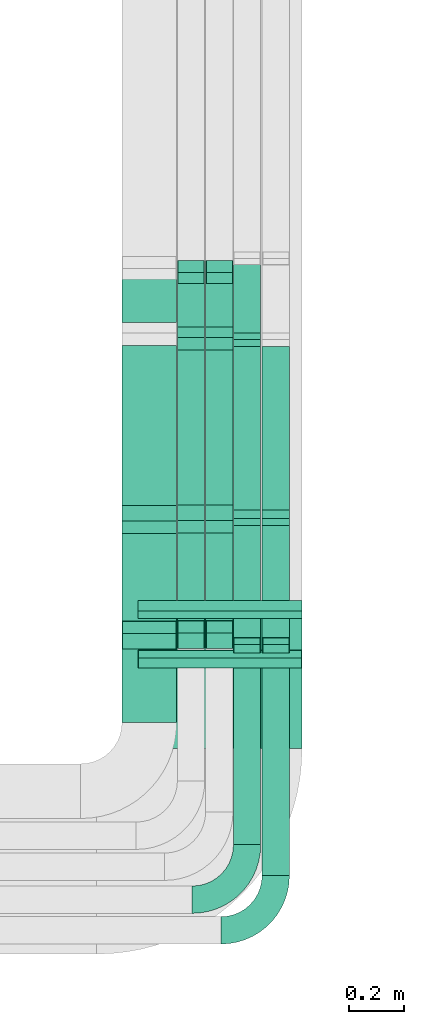
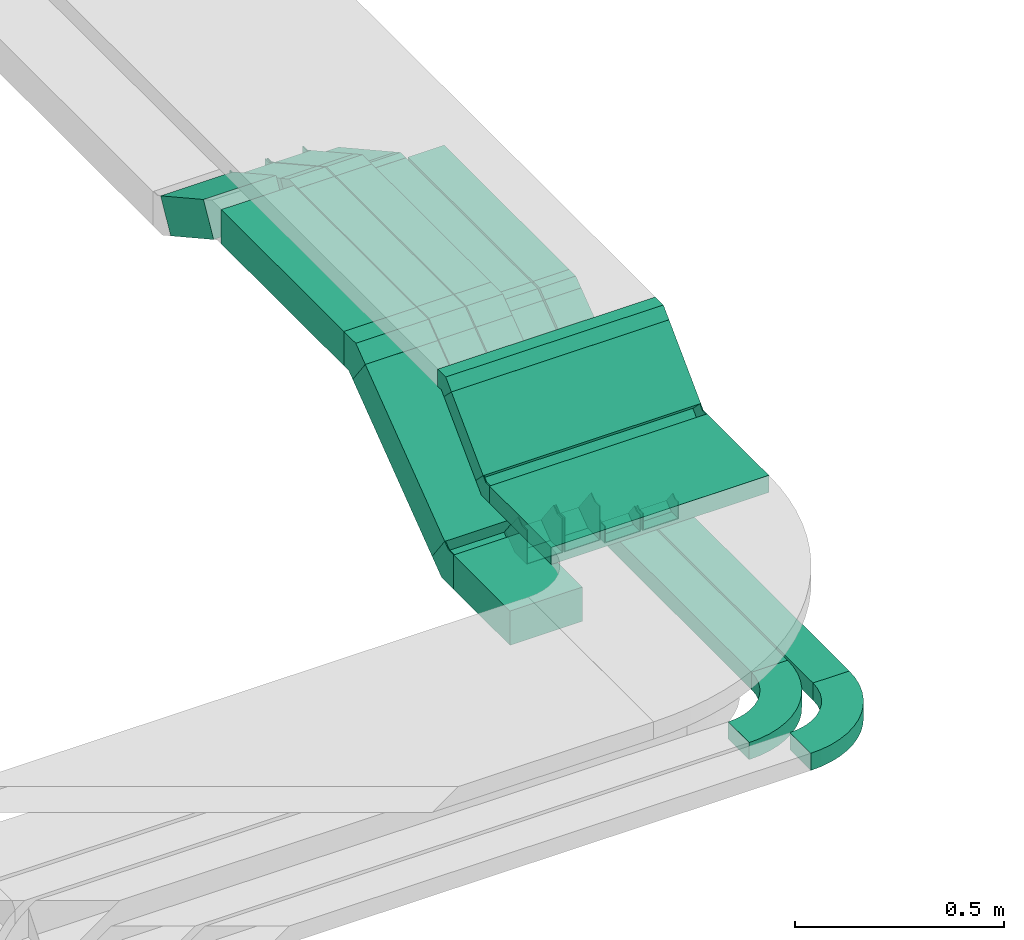
# One storey, part 24 of 38: 19 flow fittings, 19 flow segments.
"""IFC2X3 building model written with IfcOpenShell, lengths in millimetres."""

from ifc_helpers import new_model, entity, si_unit, converted_unit, derived_unit, direction, frame, frame_2d, origin, origin_2d_with_axis, place, context, subcontext, project, spatial, polyline, circle_curve, parameter, trimmed, segment, composite_curve, rectangle, outline, extrude, faceted_brep, source, transform, mapped, material, type_object, type_shapes, element, save


model = new_model("IFC2X3")

# Units and contexts
model_context = context("Model", 3, precision=0.01, world=origin(), true_north=direction((6.12303176911189e-17, 1.0)))
body_context = subcontext(model_context, "Body", "Model", "MODEL_VIEW")
ifc_project = project(units=[si_unit("LENGTHUNIT", "METRE", prefix="MILLI"), si_unit("AREAUNIT", "SQUARE_METRE"), si_unit("VOLUMEUNIT", "CUBIC_METRE"), converted_unit("PLANEANGLEUNIT", "DEGREE", entity("IfcRatioMeasure", 0.0174532925199433), si_unit("PLANEANGLEUNIT", "RADIAN"), dimensions=[0, 0, 0, 0, 0, 0, 0]), si_unit("MASSUNIT", "GRAM", prefix="KILO"), derived_unit("MASSDENSITYUNIT", [(si_unit("MASSUNIT", "GRAM", prefix="KILO"), 1), (si_unit("LENGTHUNIT", "METRE"), -3)]), derived_unit("MOMENTOFINERTIAUNIT", [(si_unit("LENGTHUNIT", "METRE"), 4)]), si_unit("TIMEUNIT", "SECOND"), si_unit("FREQUENCYUNIT", "HERTZ"), si_unit("THERMODYNAMICTEMPERATUREUNIT", "DEGREE_CELSIUS"), derived_unit("THERMALTRANSMITTANCEUNIT", [(si_unit("MASSUNIT", "GRAM", prefix="KILO"), 1), (si_unit("THERMODYNAMICTEMPERATUREUNIT", "KELVIN"), -1), (si_unit("TIMEUNIT", "SECOND"), -3)]), derived_unit("VOLUMETRICFLOWRATEUNIT", [(si_unit("LENGTHUNIT", "METRE"), 3), (si_unit("TIMEUNIT", "SECOND"), -1)]), derived_unit("MASSFLOWRATEUNIT", [(si_unit("MASSUNIT", "GRAM", prefix="KILO"), 1), (si_unit("TIMEUNIT", "SECOND"), -1)]), derived_unit("ROTATIONALFREQUENCYUNIT", [(si_unit("TIMEUNIT", "SECOND"), -1)]), si_unit("ELECTRICCURRENTUNIT", "AMPERE"), si_unit("ELECTRICVOLTAGEUNIT", "VOLT"), si_unit("POWERUNIT", "WATT"), si_unit("FORCEUNIT", "NEWTON", prefix="KILO"), si_unit("ILLUMINANCEUNIT", "LUX"), si_unit("LUMINOUSFLUXUNIT", "LUMEN"), si_unit("LUMINOUSINTENSITYUNIT", "CANDELA"), derived_unit("USERDEFINED", [(si_unit("MASSUNIT", "GRAM", prefix="KILO"), -1), (si_unit("LENGTHUNIT", "METRE"), -2), (si_unit("TIMEUNIT", "SECOND"), 3), (si_unit("LUMINOUSFLUXUNIT", "LUMEN"), 1)]), derived_unit("LINEARVELOCITYUNIT", [(si_unit("LENGTHUNIT", "METRE"), 1), (si_unit("TIMEUNIT", "SECOND"), -1)]), si_unit("PRESSUREUNIT", "PASCAL"), derived_unit("USERDEFINED", [(si_unit("LENGTHUNIT", "METRE"), -2), (si_unit("MASSUNIT", "GRAM", prefix="KILO"), 1), (si_unit("TIMEUNIT", "SECOND"), -2)]), derived_unit("LINEARFORCEUNIT", [(si_unit("MASSUNIT", "GRAM", prefix="KILO"), 1), (si_unit("LENGTHUNIT", "METRE"), 1), (si_unit("TIMEUNIT", "SECOND"), -2), (si_unit("LENGTHUNIT", "METRE"), -1)]), derived_unit("PLANARFORCEUNIT", [(si_unit("MASSUNIT", "GRAM", prefix="KILO"), 1), (si_unit("LENGTHUNIT", "METRE"), 1), (si_unit("TIMEUNIT", "SECOND"), -2), (si_unit("LENGTHUNIT", "METRE"), -2)])], contexts=[model_context])

# Site, building, storey
site_placement = place(None, frame((0.0, -0.00077364408347762, 0.0)))
site = spatial("IfcSite", under=ifc_project, at=site_placement, CompositionType="ELEMENT")
building_placement = place(site_placement, origin())
building = spatial("IfcBuilding", under=site, at=building_placement, CompositionType="ELEMENT")
storey_placement = place(building_placement, frame((0.0, 0.0, 4200.0)))
storey = spatial("IfcBuildingStorey", under=building, at=storey_placement, CompositionType="ELEMENT", Elevation=4200.0)

# Flow segments
cable_carrier_segment_type = type_object("IfcCableCarrierSegmentType", PredefinedType="CABLETRAYSEGMENT")
flow_segment_1_placement = place(storey_placement, frame((38752.8222600308, 1188.25428830449, 2836.0)))
element("IfcFlowSegment", 1, at=flow_segment_1_placement, inside=storey, type_object=cable_carrier_segment_type, context=body_context, shape_type="SweptSolid", body=[
    extrude(rectangle(XDim=269.298544442396, YDim=199.999999999998, at=frame_2d((7.105427357601e-14, 0.0), x_axis=(1.0, 0.0))), frame((100.0, 134.649272221204, 0.0), z_axis=(0.0, 0.0, 1.0), x_axis=(0.0, 1.0, 0.0)), (0.0, 0.0, 1.0), 99.9999999999989),
])
flow_segment_2_placement = place(storey_placement, frame((38752.8222600308, 1499.6458365705, 2870.22057105848)))
element("IfcFlowSegment", 2, at=flow_segment_2_placement, inside=storey, type_object=cable_carrier_segment_type, context=body_context, shape_type="SweptSolid", body=[
    extrude(rectangle(XDim=99.9999999999993, YDim=474.734982904556, at=frame_2d((-1.13686837721616e-13, 7.46069872548105e-14), x_axis=(0.0, 1.0))), frame((0.0, 219.660858762238, 182.783097866262), z_axis=(1.0, 0.0, 0.0), x_axis=(0.0, 0.798635510047289, 0.601815023152054)), (0.0, 0.0, 1.0), 199.999999999998),
])
flow_segment_3_placement = place(storey_placement, frame((38752.8222600308, 2602.8031562133, 3047.05712903482)))
element("IfcFlowSegment", 3, at=flow_segment_3_placement, inside=storey, type_object=cable_carrier_segment_type, context=body_context, shape_type="SweptSolid", body=[
    extrude(rectangle(XDim=100.0, YDim=234.381167082299, at=frame_2d((0.0, 0.0), x_axis=(0.0, 1.0))), frame((0.0, 126.737674868573, 100.546107660004), z_axis=(1.0, 0.0, 0.0), x_axis=(0.0, -0.87461970713942, 0.484809620246293)), (0.0, 0.0, 1.0), 199.999999999998),
])
flow_segment_4_placement = place(storey_placement, frame((38752.8222600308, 1981.06055791858, 3170.00733784943)))
element("IfcFlowSegment", 4, at=flow_segment_4_placement, inside=storey, type_object=cable_carrier_segment_type, context=body_context, shape_type="SweptSolid", body=[
    extrude(rectangle(XDim=585.704970645481, YDim=199.999999999998, at=origin_2d_with_axis()), frame((100.0, 292.852485322742, 0.0), z_axis=(0.0, 0.0, 1.0), x_axis=(0.0, -1.0, 0.0)), (0.0, 0.0, 1.0), 99.9999999999989),
])
flow_segment_5_placement = place(storey_placement, frame((38955.522261068, 2586.69064991435, 3046.85799349464)))
element("IfcFlowSegment", 5, at=flow_segment_5_placement, inside=storey, type_object=cable_carrier_segment_type, context=body_context, shape_type="SweptSolid", body=[
    extrude(rectangle(XDim=100.0, YDim=100.000000000003, at=frame_2d((-1.31450406115619e-13, 4.33431068813661e-12), x_axis=(1.0, 0.0))), frame((50.0, 24.2404810123145, 157.995913727656), z_axis=(0.0, 0.87461970713944, -0.484809620246257), x_axis=(0.0, 0.484809620246257, 0.87461970713944)), (0.0, 0.0, 1.0), 235.690307285242),
])
flow_segment_6_placement = place(storey_placement, frame((38955.522261068, 1982.94037717017, 3170.44288607389)))
element("IfcFlowSegment", 6, at=flow_segment_6_placement, inside=storey, type_object=cable_carrier_segment_type, context=body_context, shape_type="SweptSolid", body=[
    extrude(rectangle(XDim=567.712645094914, YDim=100.000000000003, at=frame_2d((0.0, 4.33431068813661e-12), x_axis=(1.0, 0.0))), frame((50.0, 283.856322547457, 0.0), z_axis=(0.0, 0.0, 1.0), x_axis=(0.0, -1.0, 0.0)), (0.0, 0.0, 1.0), 99.9999999999989),
])
flow_segment_7_placement = place(storey_placement, frame((38955.522261068, 1500.94766380633, 2870.22057105848)))
element("IfcFlowSegment", 7, at=flow_segment_7_placement, inside=storey, type_object=cable_carrier_segment_type, context=body_context, shape_type="SweptSolid", body=[
    extrude(rectangle(XDim=99.9999999999994, YDim=475.458707317659, at=frame_2d((2.1316282072803e-13, 5.15143483426073e-13), x_axis=(0.0, 1.0))), frame((0.0, 219.949854770123, 183.000871978493), z_axis=(1.0, 0.0, 0.0), x_axis=(0.0, -0.798635510047221, -0.601815023152144)), (0.0, 0.0, 1.0), 100.000000000003),
])
flow_segment_8_placement = place(storey_placement, frame((39058.8222600307, 2586.69064991435, 3046.85799349464)))
element("IfcFlowSegment", 8, at=flow_segment_8_placement, inside=storey, type_object=cable_carrier_segment_type, context=body_context, shape_type="SweptSolid", body=[
    extrude(rectangle(XDim=99.9999999999999, YDim=99.9999999999946, at=frame_2d((-1.35003119794419e-13, 0.0), x_axis=(1.0, 0.0))), frame((50.0, 24.2404810123129, 157.995913727657), z_axis=(0.0, 0.874619707139443, -0.484809620246252), x_axis=(0.0, 0.484809620246252, 0.874619707139443)), (0.0, 0.0, 1.0), 235.690307285251),
])
flow_segment_9_placement = place(storey_placement, frame((39058.8222600307, 1982.94037717018, 3170.44288607388)))
element("IfcFlowSegment", 9, at=flow_segment_9_placement, inside=storey, type_object=cable_carrier_segment_type, context=body_context, shape_type="SweptSolid", body=[
    extrude(rectangle(XDim=567.712645094897, YDim=99.9999999999946, at=frame_2d((1.4210854715202e-13, 0.0), x_axis=(1.0, 0.0))), frame((50.0, 283.856322547448, 0.0), z_axis=(0.0, 0.0, 1.0), x_axis=(0.0, -1.0, 0.0)), (0.0, 0.0, 1.0), 99.9999999999989),
])
flow_segment_10_placement = place(storey_placement, frame((39058.8222600307, 1500.94766380627, 2870.22057105847)))
element("IfcFlowSegment", 10, at=flow_segment_10_placement, inside=storey, type_object=cable_carrier_segment_type, context=body_context, shape_type="SweptSolid", body=[
    extrude(rectangle(XDim=100.000000000001, YDim=99.9999999999946, at=frame_2d((-6.75015598972095e-13, 0.0), x_axis=(1.0, 0.0))), frame((50.0, 30.0907511576032, 39.9317755023651), z_axis=(0.0, 0.798635510047284, 0.60181502315206), x_axis=(0.0, -0.60181502315206, 0.798635510047284)), (0.0, 0.0, 1.0), 475.45870731771),
])
flow_segment_11_placement = place(storey_placement, frame((39265.3222600308, 629.10903985203, 2836.0)))
element("IfcFlowSegment", 11, at=flow_segment_11_placement, inside=storey, type_object=cable_carrier_segment_type, context=body_context, shape_type="SweptSolid", body=[
    extrude(rectangle(XDim=813.299265565232, YDim=99.9999999999946, at=frame_2d((-8.5265128291212e-14, 0.0), x_axis=(1.0, 0.0))), frame((50.0, 406.64963278262, 0.0), z_axis=(0.0, 0.0, 1.0), x_axis=(0.0, 1.0, 0.0)), (0.0, 0.0, 1.0), 49.9999999999995),
])
flow_segment_12_placement = place(storey_placement, frame((39160.3222600308, 2587.50128862597, 3037.45447153009)))
element("IfcFlowSegment", 12, at=flow_segment_12_placement, inside=storey, type_object=cable_carrier_segment_type, context=body_context, shape_type="SweptSolid", body=[
    extrude(rectangle(XDim=50.0000000000005, YDim=313.118699211561, at=frame_2d((-2.41584530158434e-13, -1.31450406115619e-13), x_axis=(0.0, 1.0))), frame((0.0, 149.050133008307, 97.7669715068614), z_axis=(1.0, 0.0, 0.0), x_axis=(0.0, -0.874619707139457, 0.484809620246227)), (0.0, 0.0, 1.0), 99.9999999999946),
])
flow_segment_13_placement = place(storey_placement, frame((39160.3222600308, 1966.21061119508, 3195.44288607388)))
element("IfcFlowSegment", 13, at=flow_segment_13_placement, inside=storey, type_object=cable_carrier_segment_type, context=body_context, shape_type="SweptSolid", body=[
    extrude(rectangle(XDim=597.373290287799, YDim=99.9999999999946, at=frame_2d((-1.4210854715202e-13, 0.0), x_axis=(1.0, 0.0))), frame((50.0, 298.6866451439, 0.0), z_axis=(0.0, 0.0, 1.0), x_axis=(0.0, -1.0, 0.0)), (0.0, 0.0, 1.0), 49.9999999999995),
])
flow_segment_14_placement = place(storey_placement, frame((39160.3222600308, 1469.45593366207, 2855.11823431198)))
element("IfcFlowSegment", 14, at=flow_segment_14_placement, inside=storey, type_object=cable_carrier_segment_type, context=body_context, shape_type="SweptSolid", body=[
    extrude(rectangle(XDim=49.9999999999999, YDim=550.459242796006, at=frame_2d((1.13686837721616e-13, -8.34887714518118e-14), x_axis=(0.0, 1.0))), frame((0.0, 234.853524644111, 185.603208724962), z_axis=(1.0, 0.0, 0.0), x_axis=(0.0, -0.798635510047261, -0.60181502315209)), (0.0, 0.0, 1.0), 99.9999999999945),
])
flow_segment_15_placement = place(storey_placement, frame((39160.3222600308, 741.347211263791, 2836.0)))
element("IfcFlowSegment", 15, at=flow_segment_15_placement, inside=storey, type_object=cable_carrier_segment_type, context=body_context, shape_type="SweptSolid", body=[
    extrude(rectangle(XDim=701.061094153478, YDim=99.9999999999946, at=frame_2d((8.5265128291212e-14, 0.0), x_axis=(1.0, 0.0))), frame((50.0, 350.53054707674, 0.0), z_axis=(0.0, 0.0, 1.0), x_axis=(0.0, 1.0, 0.0)), (0.0, 0.0, 1.0), 49.9999999999995),
])
flow_segment_16_placement = place(storey_placement, frame((39265.3222600308, 1966.21061119508, 3195.44288607389)))
element("IfcFlowSegment", 16, at=flow_segment_16_placement, inside=storey, type_object=cable_carrier_segment_type, context=body_context, shape_type="SweptSolid", body=[
    extrude(rectangle(XDim=597.373290287805, YDim=99.9999999999946, at=frame_2d((-2.8421709430404e-13, 0.0), x_axis=(1.0, 0.0))), frame((50.0, 298.686645143902, 0.0), z_axis=(0.0, 0.0, 1.0), x_axis=(0.0, -1.0, 0.0)), (0.0, 0.0, 1.0), 49.9999999999995),
])
flow_segment_17_placement = place(storey_placement, frame((39265.3222600308, 1469.45593366206, 2855.11823431198)))
element("IfcFlowSegment", 17, at=flow_segment_17_placement, inside=storey, type_object=cable_carrier_segment_type, context=body_context, shape_type="SweptSolid", body=[
    extrude(rectangle(XDim=49.9999999999999, YDim=550.459242796012, at=frame_2d((-4.54747350886464e-13, -3.46389583683049e-13), x_axis=(0.0, 1.0))), frame((0.0, 234.853524644114, 185.603208724963), z_axis=(1.0, 0.0, 0.0), x_axis=(0.0, -0.798635510047262, -0.60181502315209)), (0.0, 0.0, 1.0), 99.9999999999946),
])
flow_segment_18_placement = place(storey_placement, frame((38811.3840639797, 1417.47655152937, 3135.81954925734)))
element("IfcFlowSegment", 18, at=flow_segment_18_placement, inside=storey, type_object=cable_carrier_segment_type, context=body_context, shape_type="SweptSolid", body=[
    extrude(rectangle(XDim=49.9999999999995, YDim=214.759813245738, at=frame_2d((-3.69482222595252e-13, -3.80140363631654e-13), x_axis=(0.0, 1.0))), frame((0.0, 93.6067296658767, 93.6067296658662), z_axis=(1.0, 0.0, 0.0), x_axis=(0.0, -0.707106781186602, -0.707106781186493)), (0.0, 0.0, 1.0), 600.000000000002),
])
flow_segment_19_placement = place(storey_placement, frame((38811.3840639797, 1092.65700227203, 3108.85255784634)))
element("IfcFlowSegment", 19, at=flow_segment_19_placement, inside=storey, type_object=cable_carrier_segment_type, context=body_context, shape_type="SweptSolid", body=[
    extrude(rectangle(XDim=295.070811915794, YDim=600.000000000002, at=frame_2d((1.27897692436818e-13, 0.0), x_axis=(1.0, 0.0))), frame((300.0, 147.535405957897, 0.0), z_axis=(0.0, 0.0, 1.0), x_axis=(0.0, 1.0, 0.0)), (0.0, 0.0, 1.0), 49.9999999999995),
])

# Flow fittings
ifc_material = material()
cable_carrier_fitting_type_1 = type_object("IfcCableCarrierFittingType", Name="470_DKC_S5_Variable Angle Elbow 0-45:-", PredefinedType="NOTDEFINED", material=ifc_material)
shared_shape_1 = source(origin(), body_context, "Body", "SweptSolid", [
    extrude(outline(composite_curve([segment(polyline([(-100.750000000001, -150.25), (-99.7499999999994, -150.25)]), True, "CONTINUOUS"), segment(trimmed(circle_curve(frame_2d((-99.7499999999997, 99.7499999999995), x_axis=(0.0, -1.0)), 250.0), [parameter(0.0)], [parameter(90.0000000000001)], True, "PARAMETER"), True, "CONTINUOUS"), segment(polyline([(150.25, 99.75), (150.25, 100.749999999999)]), True, "CONTINUOUS"), segment(polyline([(150.25, 100.749999999999), (50.25, 100.75)]), True, "CONTINUOUS"), segment(polyline([(50.25, 100.75), (50.25, 99.7499999999998)]), True, "CONTINUOUS"), segment(trimmed(circle_curve(frame_2d((-99.7499999999997, 99.7499999999995), x_axis=(0.0, -1.0)), 150.0), [parameter(0.0)], [parameter(90.0000000000001)], True, "PARAMETER"), False, "CONTINUOUS"), segment(polyline([(-99.7499999999994, -50.2500000000003), (-100.750000000001, -50.2500000000003)]), True, "CONTINUOUS"), segment(polyline([(-100.750000000001, -50.2500000000003), (-100.750000000001, -150.25)]), True, "CONTINUOUS")], self_intersect=False)), frame((-100.249999999991, 100.249999999992, -25.0)), (0.0, 0.0, 1.0), 49.9999999999997),
])
type_shapes(cable_carrier_fitting_type_1, [shared_shape_1])
for number, where, name in (
    (20, (39210.3222600308, 540.347211263809, 2861.0), "470_DKC_S5_Variable Angle Elbow 0-45:-"),
    (21, (39315.3222600308, 428.10903985205, 2861.0), "470_DKC_S5_Variable Angle Elbow 0-45:-"),
):
    element("IfcFlowFitting", number, at=place(storey_placement, frame(where)), inside=storey, type_object=cable_carrier_fitting_type_1, material=ifc_material, Name=name, ObjectType="470_DKC_S5_Variable Angle Elbow 0-45:-", context=body_context, shape_type="MappedRepresentation", body=[
        mapped(shared_shape_1, transform((0.0, 0.0, 0.0), scale=1.0)),
    ])
cable_carrier_fitting_type_2 = type_object("IfcCableCarrierFittingType", PredefinedType="NOTDEFINED", material=ifc_material)
shared_shape_2 = source(origin(), body_context, "Body", "Brep", [
    faceted_brep([(-40.1325085477228, -50.0, 100.0), (-40.1325085477225, 50.0, 100.0), (-40.1325085477225, 50.0, 97.4600000101635), (-40.1325085477228, -47.4600000101599, 97.4600000101635), (-40.1325085477228, -47.4600000101599, -97.4600000101564), (-40.1325085477225, 50.0, -97.4600000101564), (-40.1325085477225, 50.0, -100.0), (-40.1325085477228, -50.0, -100.0), (62.1419975910926, -15.7794289415615, 100.0), (62.1419975910926, -15.7794289415615, -100.0), (1.96049527588045, 64.0841220631622, -100.0), (1.96049527588044, 64.0841220631622, -97.4600000101564), (60.6133874384007, -13.7508947541557, -97.4600000101564), (60.6133874384007, -13.7508947541557, 97.4600000101635), (1.96049527588045, 64.0841220631622, 97.4600000101635), (1.96049527588044, 64.0841220631622, 100.0), (16.7297659751066, -50.0, 100.0), (-16.7297659751058, 50.0, 100.0), (-16.7297659751058, 50.0, 97.4600000101635), (15.8798938669706, -47.46000001016, 97.4600000101635), (15.8798938669706, -47.46000001016, -97.4600000101564), (-16.7297659751058, 50.0, -97.4600000101564), (-16.7297659751058, 50.0, -100.0), (16.7297659751065, -50.0, -100.0)], [[[0, 1, 2, 3, 4, 5, 6, 7]], [[8, 9, 10, 11, 12, 13, 14, 15]], [[1, 0, 16, 8, 15, 17]], [[2, 1, 17, 18]], [[3, 2, 18, 14, 13, 19]], [[4, 3, 19, 20]], [[5, 4, 20, 12, 11, 21]], [[6, 5, 21, 22]], [[7, 6, 22, 10, 9, 23]], [[0, 7, 23, 16]], [[18, 17, 15, 14]], [[20, 19, 13, 12]], [[22, 21, 11, 10]], [[16, 23, 9, 8]]]),
])
type_shapes(cable_carrier_fitting_type_2, [shared_shape_2])
for number, where, z_axis, x_axis in (
    (22, (38852.8222600308, 1497.68534129461, 2886.0), (1.0, 0.0, 0.0), (0.0, 1.0, 0.0)),
    (23, (38852.8222600308, 1940.92804937086, 3220.00733784943), (-1.0, 0.0, 0.0), (0.0, 0.798635510047237, 0.601815023152122)),
):
    element("IfcFlowFitting", number, at=place(storey_placement, frame(where, z_axis=z_axis, x_axis=x_axis)), inside=storey, type_object=cable_carrier_fitting_type_2, material=ifc_material, context=body_context, shape_type="MappedRepresentation", body=[
        mapped(shared_shape_2, transform((0.0, 0.0, 0.0), scale=1.0)),
    ])
cable_carrier_fitting_type_3 = type_object("IfcCableCarrierFittingType", PredefinedType="NOTDEFINED", material=ifc_material)
shared_shape_3 = source(origin(), body_context, "Body", "Brep", [
    faceted_brep([(-32.1548463573786, -50.0, 50.0), (-32.1548463573783, 50.0, 50.0), (-32.1548463573783, 50.0, 47.4600000101635), (-32.1548463573786, -47.4600000101599, 47.4600000101635), (-32.1548463573786, -47.4600000101599, -47.4600000101565), (-32.1548463573783, 50.0, -47.4600000101565), (-32.1548463573783, 50.0, -50.0), (-32.1548463573786, -50.0, -50.0), (52.3637433165256, -28.1420065053603, 50.0), (52.3637433165256, -28.1420065053603, -50.0), (3.88278129187567, 59.3199642085703, -50.0), (3.88278129187567, 59.3199642085703, -47.4600000101565), (51.1323268860252, -25.9204724581126, -47.4600000101565), (51.1323268860252, -25.9204724581126, 47.4600000101635), (3.88278129187567, 59.3199642085703, 47.4600000101635), (3.88278129187568, 59.3199642085703, 50.0), (12.9308792177999, -50.0, 50.0), (-12.930879217799, 50.0, 50.0), (-12.930879217799, 50.0, 47.4600000101635), (12.2739905561631, -47.46000001016, 47.4600000101635), (12.2739905561631, -47.46000001016, -47.4600000101565), (-12.930879217799, 50.0, -47.4600000101565), (-12.930879217799, 50.0, -50.0), (12.9308792177997, -50.0, -50.0)], [[[0, 1, 2, 3, 4, 5, 6, 7]], [[8, 9, 10, 11, 12, 13, 14, 15]], [[1, 0, 16, 8, 15, 17]], [[2, 1, 17, 18]], [[3, 2, 18, 14, 13, 19]], [[4, 3, 19, 20]], [[5, 4, 20, 12, 11, 21]], [[6, 5, 21, 22]], [[7, 6, 22, 10, 9, 23]], [[0, 7, 23, 16]], [[18, 17, 15, 14]], [[20, 19, 13, 12]], [[22, 21, 11, 10]], [[16, 23, 9, 8]]]),
])
type_shapes(cable_carrier_fitting_type_3, [shared_shape_3])
for number, where, z_axis, x_axis in (
    (24, (39005.522261068, 2845.1937807643, 3075.0), (-1.0, 0.0, 0.0), (0.0, -1.0, 0.0)),
    (25, (39005.522261068, 2582.80786862247, 3220.44288607389), (1.0, 0.0, 0.0), (0.0, -0.874619707139437, 0.484809620246262)),
    (26, (39108.8222600307, 2582.80786862246, 3220.44288607388), (1.0, 0.0, 0.0), (0.0, -0.874619707139437, 0.484809620246262)),
    (27, (39108.8222600307, 2845.1937807643, 3075.0), (1.0, 0.0, 0.0), (0.0, 0.874619707139419, -0.484809620246296)),
):
    element("IfcFlowFitting", number, at=place(storey_placement, frame(where, z_axis=z_axis, x_axis=x_axis)), inside=storey, type_object=cable_carrier_fitting_type_3, material=ifc_material, context=body_context, shape_type="MappedRepresentation", body=[
        mapped(shared_shape_3, transform((0.0, 0.0, 0.0), scale=1.0)),
    ])
cable_carrier_fitting_type_4 = type_object("IfcCableCarrierFittingType", PredefinedType="NOTDEFINED", material=ifc_material)
shared_shape_4 = source(origin(), body_context, "Body", "Brep", [
    faceted_brep([(-40.1325085477206, -50.0, 50.0), (-40.1325085477203, 50.0, 50.0), (-40.1325085477203, 50.0, 47.4600000101635), (-40.1325085477206, -47.4600000101599, 47.4600000101635), (-40.1325085477206, -47.4600000101599, -47.4600000101565), (-40.1325085477203, 50.0, -47.4600000101565), (-40.1325085477203, 50.0, -50.0), (-40.1325085477206, -50.0, -50.0), (62.1419975910903, -15.7794289415652, 50.0), (62.1419975910903, -15.7794289415652, -50.0), (1.96049527588111, 64.0841220631608, -50.0), (1.9604952758811, 64.0841220631608, -47.4600000101565), (60.6133874383984, -13.7508947541593, -47.4600000101564), (60.6133874383984, -13.7508947541593, 47.4600000101635), (1.96049527588111, 64.0841220631608, 47.4600000101635), (1.9604952758811, 64.0841220631608, 50.0), (16.7297659751056, -50.0, 50.0), (-16.7297659751048, 50.0, 50.0), (-16.7297659751048, 50.0, 47.4600000101635), (15.8798938669696, -47.46000001016, 47.4600000101635), (15.8798938669696, -47.46000001016, -47.4600000101565), (-16.7297659751048, 50.0, -47.4600000101565), (-16.7297659751048, 50.0, -50.0), (16.7297659751055, -50.0, -50.0)], [[[0, 1, 2, 3, 4, 5, 6, 7]], [[8, 9, 10, 11, 12, 13, 14, 15]], [[1, 0, 16, 8, 15, 17]], [[2, 1, 17, 18]], [[3, 2, 18, 14, 13, 19]], [[4, 3, 19, 20]], [[5, 4, 20, 12, 11, 21]], [[6, 5, 21, 22]], [[7, 6, 22, 10, 9, 23]], [[0, 7, 23, 16]], [[18, 17, 15, 14]], [[20, 19, 13, 12]], [[22, 21, 11, 10]], [[16, 23, 9, 8]]]),
])
type_shapes(cable_carrier_fitting_type_4, [shared_shape_4])
for number, where, z_axis, x_axis in (
    (28, (39005.522261068, 1942.80786862246, 3220.4428860739), (1.0, 0.0, 0.0), (0.0, -1.0, 0.0)),
    (29, (39005.522261068, 1498.98716853045, 2886.0), (1.0, 0.0, 0.0), (0.0, 1.0, 0.0)),
    (30, (39108.8222600307, 1942.80786862247, 3220.44288607389), (1.0, 0.0, 0.0), (0.0, -1.0, 0.0)),
    (31, (39108.8222600307, 1498.98716853039, 2886.0), (-1.0, 0.0, 0.0), (0.0, -0.79863551004726, -0.601815023152092)),
):
    element("IfcFlowFitting", number, at=place(storey_placement, frame(where, z_axis=z_axis, x_axis=x_axis)), inside=storey, type_object=cable_carrier_fitting_type_4, material=ifc_material, context=body_context, shape_type="MappedRepresentation", body=[
        mapped(shared_shape_4, transform((0.0, 0.0, 0.0), scale=1.0)),
    ])
cable_carrier_fitting_type_5 = type_object("IfcCableCarrierFittingType", PredefinedType="NOTDEFINED", material=ifc_material)
shared_shape_5 = source(origin(), body_context, "Body", "Brep", [
    faceted_brep([(-19.2239671395723, -25.0, 50.0), (-19.2239671395721, 25.0, 50.0), (-19.2239671395721, 25.0, 47.4600000101635), (-19.2239671395723, -22.4600000101599, 47.4600000101635), (-19.2239671395723, -22.4600000101599, -47.4600000101565), (-19.2239671395721, 25.0, -47.4600000101565), (-19.2239671395721, 25.0, -50.0), (-19.2239671395723, -25.0, -50.0), (28.9339010158317, -12.5455284699157, 50.0), (28.9339010158317, -12.5455284699157, -50.0), (4.6934200035067, 31.1854568870496, -50.0), (4.6934200035067, 31.1854568870496, -47.4600000101565), (27.7024845853312, -10.323994422668, -47.4600000101565), (27.7024845853312, -10.323994422668, 47.4600000101635), (4.6934200035067, 31.1854568870496, 47.4600000101635), (4.6934200035067, 31.1854568870496, 50.0), (6.46543960890015, -25.0, 50.0), (-6.46543960889936, 25.0, 50.0), (-6.46543960889936, 25.0, 47.4600000101635), (5.80855094726338, -22.46000001016, 47.4600000101635), (5.80855094726338, -22.46000001016, -47.4600000101565), (-6.46543960889936, 25.0, -47.4600000101565), (-6.46543960889935, 25.0, -50.0), (6.46543960890003, -25.0, -50.0)], [[[0, 1, 2, 3, 4, 5, 6, 7]], [[8, 9, 10, 11, 12, 13, 14, 15]], [[1, 0, 16, 8, 15, 17]], [[2, 1, 17, 18]], [[3, 2, 18, 14, 13, 19]], [[4, 3, 19, 20]], [[5, 4, 20, 12, 11, 21]], [[6, 5, 21, 22]], [[7, 6, 22, 10, 9, 23]], [[0, 7, 23, 16]], [[18, 17, 15, 14]], [[20, 19, 13, 12]], [[22, 21, 11, 10]], [[16, 23, 9, 8]]]),
])
type_shapes(cable_carrier_fitting_type_5, [shared_shape_5])
flow_fitting_placement = place(storey_placement, frame((39210.3222600308, 2582.80786862246, 3220.44288607388), z_axis=(1.0, 0.0, 0.0), x_axis=(0.0, -0.874619707139437, 0.484809620246262)))
element("IfcFlowFitting", 32, at=flow_fitting_placement, inside=storey, type_object=cable_carrier_fitting_type_5, material=ifc_material, context=body_context, shape_type="MappedRepresentation", body=[
    mapped(shared_shape_5, transform((0.0, 0.0, 0.0), scale=1.0)),
])
cable_carrier_fitting_type_6 = type_object("IfcCableCarrierFittingType", PredefinedType="NOTDEFINED", material=ifc_material)
shared_shape_6 = source(origin(), body_context, "Body", "Brep", [
    faceted_brep([(-23.4027425726154, -25.0, 50.0), (-23.4027425726153, 25.0, 50.0), (-23.4027425726153, 25.0, 47.4600000101635), (-23.4027425726154, -22.4600000101599, 47.4600000101635), (-23.4027425726154, -22.4600000101599, -47.4600000101565), (-23.4027425726153, 25.0, -47.4600000101565), (-23.4027425726153, 25.0, -50.0), (-23.4027425726154, -25.0, -50.0), (33.7356368297886, -5.88176568802063, 50.0), (33.7356368297886, -5.88176568802063, -50.0), (3.64488567218396, 34.0500098143423, -50.0), (3.64488567218396, 34.0500098143423, -47.4600000101565), (32.2070266770967, -3.85323150061473, -47.4600000101565), (32.2070266770967, -3.85323150061474, 47.4600000101635), (3.64488567218396, 34.0500098143423, 47.4600000101635), (3.64488567218396, 34.0500098143423, 50.0), (8.36488298755307, -25.0, 50.0), (-8.36488298755224, 25.0, 50.0), (-8.36488298755224, 25.0, 47.4600000101635), (7.51501087941705, -22.46000001016, 47.4600000101635), (7.51501087941705, -22.46000001016, -47.4600000101565), (-8.36488298755224, 25.0, -47.4600000101565), (-8.36488298755224, 25.0, -50.0), (8.3648829875529, -25.0, -50.0)], [[[0, 1, 2, 3, 4, 5, 6, 7]], [[8, 9, 10, 11, 12, 13, 14, 15]], [[1, 0, 16, 8, 15, 17]], [[2, 1, 17, 18]], [[3, 2, 18, 14, 13, 19]], [[4, 3, 19, 20]], [[5, 4, 20, 12, 11, 21]], [[6, 5, 21, 22]], [[7, 6, 22, 10, 9, 23]], [[0, 7, 23, 16]], [[18, 17, 15, 14]], [[20, 19, 13, 12]], [[22, 21, 11, 10]], [[16, 23, 9, 8]]]),
])
type_shapes(cable_carrier_fitting_type_6, [shared_shape_6])
for number, where, z_axis, x_axis in (
    (33, (39210.3222600308, 1942.80786862247, 3220.44288607388), (1.0, 0.0, 0.0), (0.0, -1.0, 0.0)),
    (34, (39210.3222600308, 1465.81104798988, 2861.0), (1.0, 0.0, 0.0), (0.0, 1.0, 0.0)),
    (35, (39315.3222600308, 1942.80786862247, 3220.44288607389), (1.0, 0.0, 0.0), (0.0, -1.0, 0.0)),
    (36, (39315.3222600308, 1465.81104798988, 2861.0), (-1.0, 0.0, 0.0), (0.0, -0.798635510047259, -0.601815023152093)),
):
    element("IfcFlowFitting", number, at=place(storey_placement, frame(where, z_axis=z_axis, x_axis=x_axis)), inside=storey, type_object=cable_carrier_fitting_type_6, material=ifc_material, context=body_context, shape_type="MappedRepresentation", body=[
        mapped(shared_shape_6, transform((0.0, 0.0, 0.0), scale=1.0)),
    ])
cable_carrier_fitting_type_7 = type_object("IfcCableCarrierFittingType", PredefinedType="NOTDEFINED", material=ifc_material)
shared_shape_7 = source(origin(), body_context, "Body", "Brep", [
    faceted_brep([(-27.7817459305286, -25.0, 300.0), (-27.7817459305285, 25.0, 300.0), (-27.7817459305285, 25.0, 297.460000010164), (-27.7817459305286, -22.4600000101599, 297.460000010164), (-27.7817459305286, -22.4600000101599, -297.460000010156), (-27.7817459305285, 25.0, -297.460000010156), (-27.7817459305285, 25.0, -300.0), (-27.7817459305286, -25.0, -300.0), (37.3223304703426, 1.96699141102481, 300.0), (37.3223304703426, 1.96699141102481, -300.0), (1.96699141100568, 37.3223304703426, -300.0), (1.96699141100567, 37.3223304703426, -297.460000010156), (35.5262792533125, 3.76304262805395, -297.460000010156), (35.5262792533125, 3.76304262805395, 297.460000010164), (1.96699141100568, 37.3223304703426, 297.460000010164), (1.96699141100568, 37.3223304703426, 300.0), (10.3553390593318, -25.0, 300.0), (-10.355339059331, 25.0, 300.0), (-10.355339059331, 25.0, 297.460000010164), (9.30323661511198, -22.46000001016, 297.460000010164), (9.30323661511198, -22.46000001016, -297.460000010156), (-10.355339059331, 25.0, -297.460000010156), (-10.355339059331, 25.0, -300.0), (10.3553390593316, -25.0, -300.0)], [[[0, 1, 2, 3, 4, 5, 6, 7]], [[8, 9, 10, 11, 12, 13, 14, 15]], [[1, 0, 16, 8, 15, 17]], [[2, 1, 17, 18]], [[3, 2, 18, 14, 13, 19]], [[4, 3, 19, 20]], [[5, 4, 20, 12, 11, 21]], [[6, 5, 21, 22]], [[7, 6, 22, 10, 9, 23]], [[0, 7, 23, 16]], [[18, 17, 15, 14]], [[20, 19, 13, 12]], [[22, 21, 11, 10]], [[16, 23, 9, 8]]]),
])
type_shapes(cable_carrier_fitting_type_7, [shared_shape_7])
for number, where, z_axis, x_axis in (
    (37, (39111.3840639797, 1606.65700227213, 3325.0), (1.0, 0.0, 0.0), (0.0, -1.0, 0.0)),
    (38, (39111.3840639797, 1415.50956011835, 3133.85255784633), (-1.0, 0.0, 0.0), (0.0, -0.707106781186596, -0.707106781186499)),
):
    element("IfcFlowFitting", number, at=place(storey_placement, frame(where, z_axis=z_axis, x_axis=x_axis)), inside=storey, type_object=cable_carrier_fitting_type_7, material=ifc_material, context=body_context, shape_type="MappedRepresentation", body=[
        mapped(shared_shape_7, transform((0.0, 0.0, 0.0), scale=1.0)),
    ])

save(model, "model.ifc")
